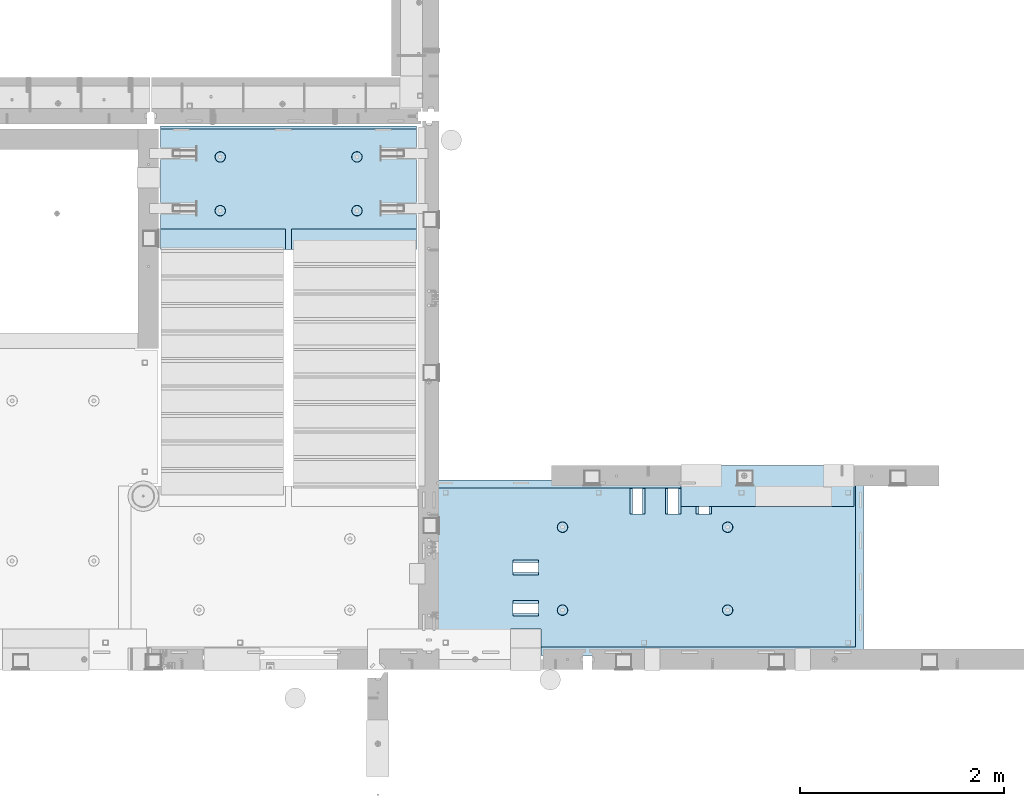
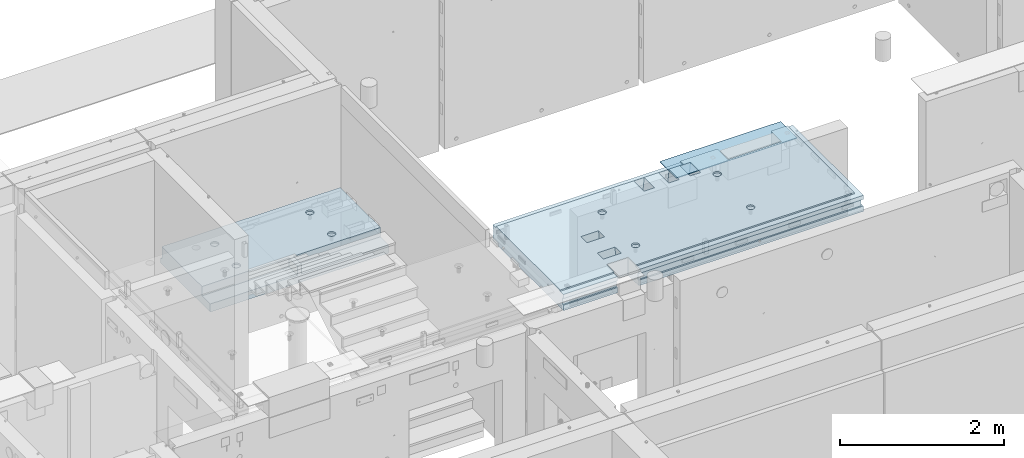
# One storey, part 150 of 264: 2 slabs, 1 plate, 3 elements without a shape of their own.
"""IFC2X3 building model written with IfcOpenShell, lengths in millimetres."""

from ifc_helpers import new_model, si_unit, frame, origin_with_axes, place, context, subcontext, project, spatial, faceted_brep, material, type_object, element, aggregate, save


model = new_model("IFC2X3")

# Units and contexts
model_context = context("Model", 3, precision=1e-05, world=origin_with_axes())
body_context = subcontext(model_context, "Body", "Model", "MODEL_VIEW")
ifc_project = project(units=[si_unit("LENGTHUNIT", "METRE", prefix="MILLI"), si_unit("AREAUNIT", "SQUARE_METRE"), si_unit("VOLUMEUNIT", "CUBIC_METRE"), si_unit("MASSUNIT", "GRAM", prefix="KILO"), si_unit("TIMEUNIT", "SECOND"), si_unit("PLANEANGLEUNIT", "RADIAN"), si_unit("SOLIDANGLEUNIT", "STERADIAN"), si_unit("THERMODYNAMICTEMPERATUREUNIT", "DEGREE_CELSIUS"), si_unit("LUMINOUSINTENSITYUNIT", "LUMEN")], contexts=[model_context])

# Site, building, storey
site_placement = place(None, origin_with_axes())
site = spatial("IfcSite", under=ifc_project, at=site_placement, CompositionType="ELEMENT")
building_placement = place(site_placement, origin_with_axes())
building = spatial("IfcBuilding", under=site, at=building_placement, CompositionType="ELEMENT")
storey_placement = place(building_placement, origin_with_axes())
storey = spatial("IfcBuildingStorey", under=building, at=storey_placement, Name="K", CompositionType="ELEMENT", Elevation=0.0)

# Assembly, slab
assembly_1_placement = place(storey_placement, origin_with_axes())
assembly_1 = element("IfcElementAssembly", 1, at=assembly_1_placement, inside=storey, AssemblyPlace="NOTDEFINED", PredefinedType="REINFORCEMENT_UNIT")
ifc_material_1 = material(Name="CONCRETE/C25/30")
slab_type_1 = type_object("IfcSlabType", PredefinedType="NOTDEFINED")
slab_1_placement = place(assembly_1_placement, frame((26570.0059390845, 15220.0026483125, 81620.0), z_axis=(-0.999999999997437, -2.26400000064461e-06, 0.0), x_axis=(-1.19799915409591e-06, 0.999999999999282, 0.0)))
slab_1 = element("IfcSlab", 2, at=slab_1_placement, type_object=slab_type_1, material=ifc_material_1, PredefinedType="FLOOR", context=body_context, shape_type="Brep", body=[
    faceted_brep([(1385.36870807312, -130.0, 2138.91585058365), (1385.36875512311, 130.0, 2163.91585058361), (1385.36894332312, 130.0, 2263.91585058343), (1385.36899037312, -130.0, 2288.91585058339), (1635.36894332267, 130.0, 2263.91538008343), (1635.36899037267, -130.0, 2288.91538008338), (1635.36875512267, 130.0, 2163.91538008361), (1635.36870807267, -130.0, 2138.91538008365), (458.263745513308, -110.000000000015, 1283.90255309084), (472.202158409184, -110.000000000015, 1291.00452918684), (483.263745513306, -110.000000000015, 1302.06611629097), (490.365721609318, -110.000000000015, 1316.00452918684), (492.812895794559, -110.000000000015, 1331.45537890559), (490.365721609318, -110.000000000015, 1346.90622862434), (483.263745513308, -110.000000000015, 1360.84464152022), (472.202158409185, -110.000000000015, 1371.90622862434), (458.263745513306, -110.000000000015, 1379.00820472035), (442.812895794559, -110.000000000015, 1381.45537890559), (427.362046075812, -110.000000000015, 1379.00820472035), (413.423633179937, -110.000000000015, 1371.90622862434), (402.362046075814, -110.000000000015, 1360.84464152021), (395.260069979802, -110.000000000015, 1346.90622862434), (392.812895794561, -110.000000000015, 1331.45537890559), (395.260069979802, -110.000000000015, 1316.00452918685), (402.362046075814, -110.000000000015, 1302.06611629097), (413.423633179937, -110.000000000015, 1291.00452918684), (427.362046075812, -110.000000000015, 1283.90255309084), (442.812895794559, -110.000000000015, 1281.45537890559), (458.966056864158, -130.0, 1281.74106100835), (442.812895794559, -130.0, 1279.18265163287), (473.538033982575, -130.0, 1289.16585419963), (485.102420500521, -130.0, 1300.73024071758), (492.527213691805, -130.0, 1315.302217836), (495.085623067285, -130.0, 1331.4553789056), (492.527213691805, -130.0, 1347.60853997519), (485.102420500521, -130.0, 1362.18051709361), (473.538033982575, -130.0, 1373.74490361155), (458.966056864158, -130.0, 1381.16969680284), (442.812895794561, -130.0, 1383.72810617832), (426.659734724963, -130.0, 1381.16969680284), (412.087757606545, -130.0, 1373.74490361156), (400.523371088597, -130.0, 1362.18051709361), (393.098577897315, -130.0, 1347.60853997519), (390.540168521833, -130.0, 1331.45537890559), (393.098577897317, -130.0, 1315.302217836), (400.523371088597, -130.0, 1300.73024071758), (412.087757606545, -130.0, 1289.16585419963), (426.659734724963, -130.0, 1281.74106100835), (1271.26411135405, -110.000000000029, 1283.90235358015), (1285.20252424993, -110.000000000029, 1291.00432967615), (1296.26411135405, -110.000000000029, 1302.06591678028), (1303.36608745006, -110.000000000029, 1316.00432967615), (1305.8132616353, -110.000000000029, 1331.4551793949), (1303.36608745006, -110.000000000029, 1346.90602911365), (1296.26411135405, -110.000000000029, 1360.84444200953), (1285.20252424992, -110.000000000029, 1371.90602911365), (1271.26411135405, -110.000000000029, 1379.00800520966), (1255.8132616353, -110.000000000029, 1381.4551793949), (1240.36241191655, -110.000000000029, 1379.00800520966), (1226.42399902068, -110.000000000029, 1371.90602911365), (1215.36241191655, -110.000000000029, 1360.84444200953), (1208.26043582054, -110.000000000029, 1346.90602911365), (1205.8132616353, -110.000000000029, 1331.45517939491), (1208.26043582054, -110.000000000029, 1316.00432967616), (1215.36241191655, -110.000000000029, 1302.06591678028), (1226.42399902068, -110.000000000029, 1291.00432967615), (1240.36241191655, -110.000000000029, 1283.90235358015), (1255.8132616353, -110.000000000029, 1281.4551793949), (1271.9664227049, -130.000000000015, 1281.74086149766), (1255.8132616353, -130.000000000015, 1279.18245212218), (1286.53839982332, -130.000000000015, 1289.16565468894), (1298.10278634126, -130.000000000015, 1300.73004120689), (1305.52757953255, -130.000000000015, 1315.30201832531), (1308.08598890803, -130.000000000015, 1331.45517939491), (1305.52757953255, -130.000000000015, 1347.6083404645), (1298.10278634126, -130.000000000015, 1362.18031758292), (1286.53839982331, -130.000000000015, 1373.74470410086), (1271.9664227049, -130.000000000015, 1381.16949729215), (1255.8132616353, -130.000000000015, 1383.72790666763), (1239.6601005657, -130.000000000015, 1381.16949729215), (1225.08812344729, -130.000000000015, 1373.74470410087), (1213.52373692934, -130.000000000015, 1362.18031758292), (1206.09894373805, -130.000000000015, 1347.6083404645), (1203.54053436257, -130.000000000015, 1331.4551793949), (1206.09894373805, -130.000000000015, 1315.30201832531), (1213.52373692934, -130.000000000015, 1300.73004120689), (1225.08812344729, -130.000000000015, 1289.16565468894), (1239.6601005657, -130.000000000015, 1281.74086149766), (1720.0078125, -110.000000000058, 4220.00537109375), (1640.00785561641, -110.000000000058, 4220.00536941853), (1640.00717842003, -110.000000000058, 1585.00001978694), (1720.00717842002, -110.000000000058, 1584.99999922694), (1700.00783630079, -49.9988643791585, 4220.00536608345), (1700.00717879947, -49.9988643791585, 1590.00006867175), (1700.00717879947, 50.0011356208415, 1590.00006867175), (1700.00783630079, 50.0011356208415, 4220.00536608345), (1720.00717879946, -49.9988643791585, 1590.00006367175), (1720.0078125, -49.9988643791585, 4220.00537109375), (1720.00717879946, 50.0011356208415, 1590.00006367175), (1720.0078125, 50.0011356208415, 4220.00537109375), (80.0079397798982, -130.0, 4220.00537109375), (80.0079397798982, -110.0, 4220.00537109375), (80.0065125017172, -110.0, 3460.00633932487), (80.0065125017172, -130.0, 3460.00633932487), (0.00793957244968624, -110.0, 4220.00537109375), (0.00650970076640078, -110.0, 3460.00648988487), (0.00793957244968624, -49.9988643791585, 4220.00537109375), (0.00650700578989927, -49.9989281829476, 3460.00648988488), (20.0078367270526, -49.9988643791585, 4220.0085543455), (20.0078367270526, 50.0011356208415, 4220.0085543455), (20.0071793252464, 50.0010725588945, 3460.00645224361), (20.0071793252337, -49.9988643791585, 3460.00645224361), (0.00793957244968624, 50.0011356208415, 4220.00537109375), (0.0065032962756959, 50.0010718170524, 3460.00648988488), (0.00793957244968624, 130.0, 4220.00537109375), (0.00650970076640078, 130.0, 3460.00648988487), (1720.0041715925, 50.0011356208415, 20.0000631346302), (1720.0041920925, -49.9988643791585, 20.0000631345902), (20.0042037196527, -49.9988643791585, 20.0000019345935), (20.0042037197236, 50.0007871208509, 20.0000019346335), (1720.0041928125, -49.9988643791585, 6.31345901638269e-05), (20.0041864226587, -49.9992128791491, 7.34271452529356e-07), (0.0, -49.9992169800098, -3.63797880709171e-12), (2.27349282795331e-05, -49.9992169800098, 20.000001214441), (1720.00415040489, -110.0, -7.82736606197432e-07), (80.0000146155362, -110.0, 0.000114017555461032), (40.0000000237706, -110.0, 0.00323799208854325), (1.81898940354586e-12, -110.000000000058, 0.0), (1720.00415600489, -110.0, 79.9999992172634), (80.0001648500238, -110.0, 80.0001140175445), (40.0000056179106, -110.0, 80.000116817555), (80.0059490995409, -110.0, 3160.00517965743), (0.00594527472276241, -110.0, 3160.00533021743), (0.00594151593395509, -49.9989533687913, 3160.00533021744), (20.0069198242309, -49.9988643791585, 3160.0052925756), (20.0069198242491, 50.0010476659954, 3160.0052925756), (2.23492861550767e-06, 50.0007830199902, 20.0000012144774), (0.00593634212964389, 50.0010466312087, 3160.00533021745), (0.0, 130.0, -1.81898940354586e-12), (0.0, 50.0007830199902, -3.63797880709171e-12), (0.00594527472276241, 130.0, 3160.00533021743), (20.0041864225386, 50.0007871208509, -3.03407432511449e-09), (1720.00415039538, 50.0011356208415, -2.60683009400964e-07), (1720.00415039063, 130.0, 3.38332029059529e-10), (1720.00421981442, -130.0, 79.9999992172052), (1720.00441940968, 130.0, 310.002169469204), (1720.00441860991, -130.000000000015, 310.002169469204), (80.0001648500238, -130.0, 80.0001140175445), (80.0059490995409, -130.0, 3160.00517965743), (260.003595423286, -130.0, 3160.00484090186), (260.003595423286, 130.0, 3160.00484090186), (260.004160025468, -130.0, 3460.00600056929), (260.004160025468, 130.0, 3460.00600056929), (1640.00785561641, -130.0, 4220.00537109375), (1720.0078125, 130.0, 4220.00537109375), (1640.00717842003, -130.000000000058, 1585.00001978694), (1720.00717842002, -130.000000000058, 1584.99999922694), (1720.00614635257, -130.000000000044, 1060.00216946755), (1720.00507025768, 130.0, 1060.00216946504), (1459.99926883107, -130.000000000015, 1060.00265880023), (1459.99926883107, 130.0, 1060.00265880023), (1459.99785733107, -130.000000000015, 310.002658801553), (1459.99785733107, 130.0, 310.002658801553), (458.266791003349, -110.000000000015, 2902.12255308797), (472.205203899226, -110.000000000015, 2909.22452918398), (483.266791003347, -110.000000000015, 2920.28611628811), (490.368767099359, -110.000000000015, 2934.22452918398), (492.8159412846, -110.000000000015, 2949.67537890273), (490.368767099359, -110.000000000015, 2965.12622862148), (483.266791003349, -110.000000000015, 2979.06464151735), (472.205203899226, -110.000000000015, 2990.12622862148), (458.266791003347, -110.000000000015, 2997.22820471749), (442.8159412846, -110.000000000015, 2999.67537890273), (427.365091565853, -110.000000000015, 2997.22820471749), (413.426678669977, -110.000000000015, 2990.12622862148), (402.365091565855, -110.000000000015, 2979.06464151735), (395.263115469843, -110.000000000015, 2965.12622862148), (392.815941284602, -110.000000000015, 2949.67537890273), (395.263115469843, -110.000000000015, 2934.22452918399), (402.365091565855, -110.000000000015, 2920.2861162881), (413.426678669977, -110.000000000015, 2909.22452918398), (427.365091565855, -110.000000000015, 2902.12255308797), (442.8159412846, -110.000000000015, 2899.67537890273), (458.969102354198, -130.0, 2899.96106100548), (442.8159412846, -130.0, 2897.40265163), (473.541079472616, -130.0, 2907.38585419677), (485.105465990562, -130.0, 2918.95024071472), (492.530259181845, -130.0, 2933.52221783313), (495.088668557326, -130.0, 2949.67537890273), (492.530259181845, -130.0, 2965.82853997233), (485.105465990562, -130.0, 2980.40051709074), (473.541079472616, -130.0, 2991.96490360869), (458.969102354198, -130.0, 2999.38969679998), (442.815941284602, -130.0, 3001.94810617546), (426.662780215003, -130.0, 2999.38969679998), (412.090803096586, -130.0, 2991.96490360869), (400.526416578641, -129.999999999985, 2980.40051709074), (393.101623387358, -129.999999999985, 2965.82853997233), (390.543214011877, -129.999999999985, 2949.67537890273), (393.10162338736, -129.999999999985, 2933.52221783313), (400.526416578638, -130.0, 2918.95024071472), (412.090803096586, -130.0, 2907.38585419677), (426.662780215003, -130.0, 2899.96106100548), (1271.26715684409, -110.000000000029, 2902.12235357728), (1285.20556973997, -110.000000000029, 2909.22432967329), (1296.26715684409, -110.000000000029, 2920.28591677742), (1303.3691329401, -110.000000000029, 2934.22432967329), (1305.81630712534, -110.000000000029, 2949.67517939204), (1303.3691329401, -110.000000000029, 2965.12602911079), (1296.26715684409, -110.000000000029, 2979.06444200667), (1285.20556973996, -110.000000000029, 2990.12602911079), (1271.26715684409, -110.000000000029, 2997.2280052068), (1255.81630712534, -110.000000000029, 2999.67517939204), (1240.36545740659, -110.000000000029, 2997.2280052068), (1226.42704451072, -110.000000000029, 2990.12602911079), (1215.36545740659, -110.000000000029, 2979.06444200666), (1208.26348131059, -110.000000000029, 2965.12602911079), (1205.81630712534, -110.000000000029, 2949.67517939204), (1208.26348131059, -110.000000000029, 2934.2243296733), (1215.36545740659, -110.000000000029, 2920.28591677741), (1226.42704451072, -110.000000000029, 2909.22432967329), (1240.36545740659, -110.000000000029, 2902.12235357728), (1255.81630712534, -110.000000000029, 2899.67517939204), (1271.96946819494, -130.000000000015, 2899.96086149479), (1255.81630712534, -130.000000000015, 2897.40245211931), (1286.54144531336, -130.000000000015, 2907.38565468608), (1298.1058318313, -130.000000000015, 2918.95004120403), (1305.53062502259, -130.000000000015, 2933.52201832244), (1308.08903439807, -130.000000000015, 2949.67517939204), (1305.53062502259, -130.000000000015, 2965.82834046164), (1298.1058318313, -130.000000000015, 2980.40031758005), (1286.54144531335, -130.000000000015, 2991.964704098), (1271.96946819494, -130.000000000015, 2999.38949728928), (1255.81630712534, -130.000000000015, 3001.94790666477), (1239.66314605574, -130.000000000015, 2999.38949728929), (1225.09116893733, -130.000000000015, 2991.964704098), (1213.52678241938, -130.000000000015, 2980.40031758005), (1206.10198922809, -130.000000000015, 2965.82834046164), (1203.54357985261, -130.000000000015, 2949.67517939204), (1206.10198922809, -130.000000000015, 2933.52201832244), (1213.52678241938, -130.000000000015, 2918.95004120403), (1225.09116893733, -130.000000000015, 2907.38565468608), (1239.66314605574, -130.000000000015, 2899.96086149479), (535.006335132097, -130.0, 3435.00760126515), (510.006335132142, 130.0, 3435.00764831515), (510.005864632141, 130.0, 3185.00764831559), (535.005864632096, -130.0, 3185.00760126559), (385.006335132362, -130.0, 3435.00788356515), (410.006335132319, 130.0, 3435.00783651515), (385.005864632361, -130.0, 3185.00788356559), (410.005864632318, 130.0, 3185.00783651559), (935.006335131389, -130.0, 3435.00684846515), (910.006335131433, 130.0, 3435.00689551515), (910.005864631432, 130.0, 3185.00689551559), (935.005864631388, -130.0, 3185.00684846559), (785.006335131655, -130.0, 3435.00713076515), (810.006335131611, 130.0, 3435.00708371515), (785.005864631654, -130.0, 3185.00713076559), (810.00586463161, 130.0, 3185.00708371559), (1635.36776707267, -130.0, 1638.91538008453), (1635.36772002267, 130.0, 1613.91538008458), (1635.36753182267, 130.0, 1513.91538008476), (1635.36748477267, -130.0, 1488.9153800848), (1385.36776707311, -130.0, 1638.91585058454), (1385.36772002312, 130.0, 1613.91585058458), (1385.36748477311, -130.0, 1488.9158505848), (1385.36753182312, 130.0, 1513.91585058476), (1385.36833167312, -130.0, 1938.91585058401), (1635.36833167267, -130.0, 1938.915380084), (1635.36804937267, -130.0, 1788.91538008427), (1385.36804937312, -130.0, 1788.91585058427), (1635.36828462267, 130.0, 1913.91538008405), (1385.36828462312, 130.0, 1913.91585058405), (1385.36809642312, 130.0, 1813.91585058423), (1635.36809642267, 130.0, 1813.91538008423)], [[[0, 1, 2, 3]], [[4, 5, 3, 2]], [[5, 4, 6, 7]], [[7, 6, 1, 0]], [[8, 9, 10, 11, 12, 13, 14, 15, 16, 17, 18, 19, 20, 21, 22, 23, 24, 25, 26, 27]], [[28, 8, 27, 29]], [[30, 9, 8, 28]], [[31, 10, 9, 30]], [[32, 11, 10, 31]], [[33, 12, 11, 32]], [[34, 13, 12, 33]], [[35, 14, 13, 34]], [[36, 15, 14, 35]], [[37, 16, 15, 36]], [[38, 17, 16, 37]], [[39, 18, 17, 38]], [[40, 19, 18, 39]], [[41, 20, 19, 40]], [[42, 21, 20, 41]], [[43, 22, 21, 42]], [[44, 23, 22, 43]], [[45, 24, 23, 44]], [[46, 25, 24, 45]], [[47, 26, 25, 46]], [[29, 27, 26, 47]], [[48, 49, 50, 51, 52, 53, 54, 55, 56, 57, 58, 59, 60, 61, 62, 63, 64, 65, 66, 67]], [[68, 48, 67, 69]], [[70, 49, 48, 68]], [[71, 50, 49, 70]], [[72, 51, 50, 71]], [[73, 52, 51, 72]], [[74, 53, 52, 73]], [[75, 54, 53, 74]], [[76, 55, 54, 75]], [[77, 56, 55, 76]], [[78, 57, 56, 77]], [[79, 58, 57, 78]], [[80, 59, 58, 79]], [[81, 60, 59, 80]], [[82, 61, 60, 81]], [[83, 62, 61, 82]], [[84, 63, 62, 83]], [[85, 64, 63, 84]], [[86, 65, 64, 85]], [[87, 66, 65, 86]], [[69, 67, 66, 87]], [[88, 89, 90, 91]], [[92, 93, 94, 95]], [[96, 93, 92, 97]], [[98, 94, 93, 96]], [[99, 95, 94, 98]], [[100, 101, 102, 103]], [[101, 104, 105, 102]], [[104, 106, 107, 105]], [[108, 109, 110, 111]], [[109, 112, 113, 110]], [[112, 114, 115, 113]], [[116, 117, 118, 119]], [[117, 120, 121, 122, 123, 118]], [[120, 124, 125, 126, 127, 122, 121]], [[125, 124, 128, 129, 130, 126]], [[127, 126, 130, 129, 131, 132]], [[123, 122, 127, 132, 133]], [[118, 123, 133, 134]], [[119, 118, 134, 135]], [[136, 119, 135, 137]], [[138, 139, 136, 137, 140]], [[141, 142, 116, 119, 136, 139]], [[139, 138, 143, 142, 141]], [[144, 128, 124, 120, 117, 116, 142, 143, 145, 146]], [[128, 144, 147, 129]], [[129, 147, 148, 131]], [[149, 150, 140, 137, 135, 134, 133, 132, 131, 148]], [[151, 152, 150, 149]], [[103, 102, 105, 107, 111, 110, 113, 115, 152, 151]], [[106, 108, 111, 107]], [[104, 101, 100, 153, 89, 88, 97, 92, 95, 99, 154, 114, 112, 109, 108, 106]], [[155, 90, 89, 153]], [[156, 91, 90, 155]], [[154, 99, 98, 96, 97, 88, 91, 156, 157, 158]], [[157, 159, 160, 158]], [[161, 162, 160, 159]], [[146, 145, 162, 161]], [[163, 164, 165, 166, 167, 168, 169, 170, 171, 172, 173, 174, 175, 176, 177, 178, 179, 180, 181, 182]], [[183, 163, 182, 184]], [[185, 164, 163, 183]], [[186, 165, 164, 185]], [[187, 166, 165, 186]], [[188, 167, 166, 187]], [[189, 168, 167, 188]], [[190, 169, 168, 189]], [[191, 170, 169, 190]], [[192, 171, 170, 191]], [[193, 172, 171, 192]], [[194, 173, 172, 193]], [[195, 174, 173, 194]], [[196, 175, 174, 195]], [[197, 176, 175, 196]], [[198, 177, 176, 197]], [[199, 178, 177, 198]], [[200, 179, 178, 199]], [[201, 180, 179, 200]], [[202, 181, 180, 201]], [[184, 182, 181, 202]], [[203, 204, 205, 206, 207, 208, 209, 210, 211, 212, 213, 214, 215, 216, 217, 218, 219, 220, 221, 222]], [[223, 203, 222, 224]], [[225, 204, 203, 223]], [[226, 205, 204, 225]], [[227, 206, 205, 226]], [[228, 207, 206, 227]], [[229, 208, 207, 228]], [[230, 209, 208, 229]], [[231, 210, 209, 230]], [[232, 211, 210, 231]], [[233, 212, 211, 232]], [[234, 213, 212, 233]], [[235, 214, 213, 234]], [[236, 215, 214, 235]], [[237, 216, 215, 236]], [[238, 217, 216, 237]], [[239, 218, 217, 238]], [[240, 219, 218, 239]], [[241, 220, 219, 240]], [[242, 221, 220, 241]], [[224, 222, 221, 242]], [[243, 244, 245, 246]], [[247, 248, 244, 243]], [[248, 247, 249, 250]], [[246, 245, 250, 249]], [[251, 252, 253, 254]], [[255, 256, 252, 251]], [[256, 255, 257, 258]], [[254, 253, 258, 257]], [[259, 260, 261, 262]], [[260, 259, 263, 264]], [[265, 266, 264, 263]], [[262, 261, 266, 265]], [[159, 157, 156, 155, 153, 100, 103, 151, 149, 148, 147, 144, 146, 161], [3, 5, 7, 0], [267, 268, 269, 270], [263, 259, 262, 265], [255, 251, 254, 257], [247, 243, 246, 249], [241, 240, 239, 238, 237, 236, 235, 234, 233, 232, 231, 230, 229, 228, 227, 226, 225, 223, 224, 242], [201, 200, 199, 198, 197, 196, 195, 194, 193, 192, 191, 190, 189, 188, 187, 186, 185, 183, 184, 202], [86, 85, 84, 83, 82, 81, 80, 79, 78, 77, 76, 75, 74, 73, 72, 71, 70, 68, 69, 87], [46, 45, 44, 43, 42, 41, 40, 39, 38, 37, 36, 35, 34, 33, 32, 31, 30, 28, 29, 47]], [[271, 268, 267, 272]], [[270, 273, 272, 267]], [[269, 274, 273, 270]], [[268, 271, 274, 269]], [[143, 138, 140, 150, 152, 115, 114, 154, 158, 160, 162, 145], [2, 1, 6, 4], [272, 273, 274, 271], [264, 266, 261, 260], [256, 258, 253, 252], [248, 250, 245, 244]]]),
])
aggregate(assembly_1, [slab_1])

# Assembly, plate
assembly_2_placement = place(storey_placement, origin_with_axes())
assembly_2 = element("IfcElementAssembly", 3, at=assembly_2_placement, inside=storey, Name="Steel Assembly", AssemblyPlace="NOTDEFINED", PredefinedType="NOTDEFINED")
ifc_material_2 = material()
plate_type = type_object("IfcPlateType", PredefinedType="NOTDEFINED")
plate_placement = place(assembly_2_placement, frame((24780.0, 16680.0, 81725.6000003815), z_axis=(0.0, 1.0, 0.0), x_axis=(1.0, 0.0, 0.0)))
plate = element("IfcPlate", 4, at=plate_placement, type_object=plate_type, material=ifc_material_2, Name="YP", context=body_context, shape_type="Brep", body=[
    faceted_brep([(0.0, -5.0, 0.0), (0.0, -5.0, 400.0), (0.0, 5.0, 400.0), (0.0, 5.0, 0.0), (1699.99914550781, -5.0, 400.0), (1699.99914550781, 5.0, 400.0), (1699.99914550781, -5.0, 3.63797880709171e-12), (1699.99914550781, 5.0, 3.63797880709171e-12)], [[[0, 1, 2, 3]], [[1, 4, 5, 2]], [[4, 6, 7, 5]], [[6, 0, 3, 7]], [[5, 7, 3, 2]], [[6, 4, 1, 0]]]),
])
aggregate(assembly_2, [plate])

# Assembly, slab
assembly_3_placement = place(storey_placement, origin_with_axes())
assembly_3 = element("IfcElementAssembly", 5, at=assembly_3_placement, inside=storey, AssemblyPlace="NOTDEFINED", PredefinedType="REINFORCEMENT_UNIT")
slab_type_2 = type_object("IfcSlabType", PredefinedType="NOTDEFINED")
slab_2_placement = place(assembly_3_placement, frame((19680.000385927, 19200.0003517906, 80120.0), z_axis=(0.0, 1.0, 0.0), x_axis=(1.0, 0.0, 0.0)))
slab_2 = element("IfcSlab", 6, at=slab_2_placement, type_object=slab_type_2, material=ifc_material_1, PredefinedType="FLOOR", context=body_context, shape_type="Brep", body=[
    faceted_brep([(1284.99890682963, -130.0, 0.0), (1284.99890682963, 10.0003972196719, 0.0), (1284.99890682963, 10.0003972196719, 200.003967285156), (1284.99890682963, -130.0, 200.003967285156), (2510.00073788432, 10.0003972196719, 200.003967285156), (2509.998046875, 10.0003972196719, 0.0), (2510.00073788432, -130.0, 200.003967285156), (2509.998046875, 60.0, 1210.00146484375), (0.0, 60.0, 1210.00146484375), (0.0, 50.0000001803419, 1180.00146538467), (2509.998046875, 50.0000001803419, 1180.00146538467), (2509.998046875, 130.0, 1210.00146484375), (0.0, 130.0, 1210.00146484375), (2509.998046875, 130.0, 0.0), (0.0, 130.0, -1.81898940354586e-12), (1225.00073788432, 10.0003972196719, 0.0), (1225.00073788432, 10.0003972196719, 200.003967285156), (-0.00109317036549328, 10.0003972196719, 200.003967285156), (0.0, 10.0003972196719, 0.0), (1225.00073788432, -130.0, 200.003967285156), (1225.00073788432, -130.0, 0.0), (0.0, -130.0, 200.003967285156), (0.0, -130.0, 1180.00146417833), (2509.998046875, -130.0, 1180.00146417833), (1940.44809334572, -110.0, 331.258272818675), (1954.3865062416, -110.0, 338.360248914683), (1965.44809334572, -110.0, 349.42183601881), (1972.55006944173, -110.0, 363.360248914683), (1974.99724362697, -110.0, 378.811098633432), (1972.55006944173, -110.0, 394.261948352181), (1965.44809334572, -110.0, 408.200361248055), (1954.3865062416, -110.0, 419.261948352181), (1940.44809334572, -110.0, 426.363924448189), (1924.99724362697, -110.0, 428.811098633432), (1909.54639390823, -110.0, 426.363924448189), (1895.60798101235, -110.0, 419.261948352181), (1884.54639390823, -110.0, 408.200361248055), (1877.44441781222, -110.0, 394.261948352181), (1874.99724362697, -110.0, 378.811098633432), (1877.44441781222, -110.0, 363.360248914683), (1884.54639390823, -110.0, 349.42183601881), (1895.60798101235, -110.0, 338.360248914683), (1909.54639390823, -110.0, 331.258272818675), (1924.99724362697, -110.0, 328.811098633432), (1974.71156152422, -130.0, 394.964259703032), (1977.2699708997, -130.0, 378.811098633432), (1967.28676833294, -130.0, 409.536236821448), (1955.72238181499, -130.0, 421.100623339393), (1941.15040469657, -130.0, 428.52541653068), (1924.99724362697, -130.0, 431.08382590616), (1908.84408255737, -130.0, 428.52541653068), (1894.27210543896, -130.0, 421.100623339393), (1882.70771892101, -130.0, 409.536236821448), (1875.28292572973, -130.0, 394.964259703032), (1872.72451635425, -130.0, 378.811098633432), (1875.28292572973, -130.0, 362.657937563832), (1882.70771892101, -130.0, 348.085960445416), (1894.27210543896, -130.0, 336.521573927472), (1908.84408255737, -130.0, 329.096780736185), (1924.99724362697, -130.0, 326.538371360704), (1941.15040469657, -130.0, 329.096780736185), (1955.72238181499, -130.0, 336.521573927472), (1967.28676833294, -130.0, 348.085960445416), (1974.71156152422, -130.0, 362.657937563832), (1940.44809334572, -110.0, 858.458272818676), (1954.3865062416, -110.0, 865.560248914684), (1965.44809334572, -110.0, 876.62183601881), (1972.55006944173, -110.0, 890.560248914684), (1974.99724362697, -110.0, 906.011098633433), (1972.55006944173, -110.0, 921.461948352182), (1965.44809334572, -110.0, 935.400361248056), (1954.3865062416, -110.0, 946.461948352182), (1940.44809334572, -110.0, 953.56392444819), (1924.99724362697, -110.0, 956.011098633433), (1909.54639390823, -110.0, 953.56392444819), (1895.60798101235, -110.0, 946.461948352182), (1884.54639390823, -110.0, 935.400361248056), (1877.44441781222, -110.0, 921.461948352182), (1874.99724362697, -110.0, 906.011098633433), (1877.44441781222, -110.0, 890.560248914684), (1884.54639390823, -110.0, 876.62183601881), (1895.60798101235, -110.0, 865.560248914684), (1909.54639390823, -110.0, 858.458272818676), (1924.99724362697, -110.0, 856.011098633433), (1974.71156152422, -130.0, 922.164259703033), (1977.2699708997, -130.0, 906.011098633433), (1967.28676833294, -130.0, 936.736236821449), (1955.72238181499, -130.0, 948.300623339394), (1941.15040469657, -130.0, 955.72541653068), (1924.99724362697, -130.0, 958.283825906161), (1908.84408255737, -130.0, 955.72541653068), (1894.27210543896, -130.0, 948.300623339394), (1882.70771892101, -130.0, 936.736236821449), (1875.28292572973, -130.0, 922.164259703033), (1872.72451635425, -130.0, 906.011098633433), (1875.28292572973, -130.0, 889.857937563833), (1882.70771892101, -130.0, 875.285960445417), (1894.27210543896, -130.0, 863.721573927472), (1908.84408255737, -130.0, 856.296780736186), (1924.99724362697, -130.0, 853.738371360705), (1941.15040469657, -130.0, 856.296780736186), (1955.72238181499, -130.0, 863.721573927472), (1967.28676833294, -130.0, 875.285960445417), (1974.71156152422, -130.0, 889.857937563833), (569.611134800252, -110.0, 426.363924448189), (555.672721904379, -110.0, 419.261948352181), (544.611134800252, -110.0, 408.200361248055), (537.509158704244, -110.0, 394.261948352181), (535.061984519001, -110.0, 378.811098633432), (537.509158704244, -110.0, 363.360248914683), (544.611134800252, -110.0, 349.42183601881), (555.672721904379, -110.0, 338.360248914683), (569.611134800252, -110.0, 331.258272818675), (585.061984519001, -110.0, 328.811098633432), (600.51283423775, -110.0, 331.258272818675), (614.451247133624, -110.0, 338.360248914683), (625.51283423775, -110.0, 349.42183601881), (632.614810333758, -110.0, 363.360248914683), (635.061984519001, -110.0, 378.811098633432), (632.614810333758, -110.0, 394.261948352181), (625.51283423775, -110.0, 408.200361248055), (614.451247133624, -110.0, 419.261948352181), (600.51283423775, -110.0, 426.363924448189), (585.061984519001, -110.0, 428.811098633432), (634.776302416249, -130.0, 394.964259703032), (637.334711791729, -130.0, 378.811098633432), (627.351509224962, -130.0, 409.536236821448), (615.787122707017, -130.0, 421.100623339393), (601.215145588601, -130.0, 428.52541653068), (585.061984519001, -130.0, 431.08382590616), (568.908823449401, -130.0, 428.52541653068), (554.336846330985, -130.0, 421.100623339393), (542.772459813041, -130.0, 409.536236821448), (535.347666621754, -130.0, 394.964259703032), (532.789257246273, -130.0, 378.811098633432), (535.347666621754, -130.0, 362.657937563832), (542.772459813041, -130.0, 348.085960445416), (554.336846330985, -130.0, 336.521573927472), (568.908823449401, -130.0, 329.096780736185), (585.061984519001, -130.0, 326.538371360704), (601.215145588601, -130.0, 329.096780736185), (615.787122707017, -130.0, 336.521573927472), (627.351509224962, -130.0, 348.085960445416), (634.776302416249, -130.0, 362.657937563832), (569.611134800252, -110.0, 953.56392444819), (555.672721904379, -110.0, 946.461948352182), (544.611134800252, -110.0, 935.400361248056), (537.509158704244, -110.0, 921.461948352182), (535.061984519001, -110.0, 906.011098633433), (537.509158704244, -110.0, 890.560248914684), (544.611134800252, -110.0, 876.62183601881), (555.672721904379, -110.0, 865.560248914684), (569.611134800252, -110.0, 858.458272818676), (585.061984519001, -110.0, 856.011098633433), (600.51283423775, -110.0, 858.458272818676), (614.451247133624, -110.0, 865.560248914684), (625.51283423775, -110.0, 876.62183601881), (632.614810333758, -110.0, 890.560248914684), (635.061984519001, -110.0, 906.011098633433), (632.614810333758, -110.0, 921.461948352182), (625.51283423775, -110.0, 935.400361248056), (614.451247133624, -110.0, 946.461948352182), (600.51283423775, -110.0, 953.56392444819), (585.061984519001, -110.0, 956.011098633433), (634.776302416249, -130.0, 922.164259703033), (637.334711791729, -130.0, 906.011098633433), (627.351509224962, -130.0, 936.736236821449), (615.787122707017, -130.0, 948.300623339394), (601.215145588601, -130.0, 955.72541653068), (585.061984519001, -130.0, 958.283825906161), (568.908823449401, -130.0, 955.72541653068), (554.336846330985, -130.0, 948.300623339394), (542.772459813041, -130.0, 936.736236821449), (535.347666621754, -130.0, 922.164259703033), (532.789257246273, -130.0, 906.011098633433), (535.347666621754, -130.0, 889.857937563833), (542.772459813041, -130.0, 875.285960445417), (554.336846330985, -130.0, 863.721573927472), (568.908823449401, -130.0, 856.296780736186), (585.061984519001, -130.0, 853.738371360705), (601.215145588601, -130.0, 856.296780736186), (615.787122707017, -130.0, 863.721573927472), (627.351509224962, -130.0, 875.285960445417), (634.776302416249, -130.0, 889.857937563833)], [[[0, 1, 2, 3]], [[4, 2, 1, 5]], [[6, 3, 2, 4]], [[7, 8, 9, 10]], [[11, 12, 8, 7]], [[11, 13, 14, 12]], [[15, 16, 17, 18]], [[19, 16, 15, 20]], [[21, 17, 16, 19]], [[22, 9, 8, 12, 14, 18, 17, 21]], [[23, 10, 9, 22]], [[5, 13, 11, 7, 10, 23, 6, 4]], [[0, 20, 15, 18, 14, 13, 5, 1]], [[24, 25, 26, 27, 28, 29, 30, 31, 32, 33, 34, 35, 36, 37, 38, 39, 40, 41, 42, 43]], [[44, 29, 28, 45]], [[46, 30, 29, 44]], [[47, 31, 30, 46]], [[48, 32, 31, 47]], [[49, 33, 32, 48]], [[50, 34, 33, 49]], [[51, 35, 34, 50]], [[52, 36, 35, 51]], [[53, 37, 36, 52]], [[54, 38, 37, 53]], [[55, 39, 38, 54]], [[56, 40, 39, 55]], [[57, 41, 40, 56]], [[58, 42, 41, 57]], [[59, 43, 42, 58]], [[60, 24, 43, 59]], [[61, 25, 24, 60]], [[62, 26, 25, 61]], [[63, 27, 26, 62]], [[45, 28, 27, 63]], [[64, 65, 66, 67, 68, 69, 70, 71, 72, 73, 74, 75, 76, 77, 78, 79, 80, 81, 82, 83]], [[84, 69, 68, 85]], [[86, 70, 69, 84]], [[87, 71, 70, 86]], [[88, 72, 71, 87]], [[89, 73, 72, 88]], [[90, 74, 73, 89]], [[91, 75, 74, 90]], [[92, 76, 75, 91]], [[93, 77, 76, 92]], [[94, 78, 77, 93]], [[95, 79, 78, 94]], [[96, 80, 79, 95]], [[97, 81, 80, 96]], [[98, 82, 81, 97]], [[99, 83, 82, 98]], [[100, 64, 83, 99]], [[101, 65, 64, 100]], [[102, 66, 65, 101]], [[103, 67, 66, 102]], [[85, 68, 67, 103]], [[104, 105, 106, 107, 108, 109, 110, 111, 112, 113, 114, 115, 116, 117, 118, 119, 120, 121, 122, 123]], [[124, 119, 118, 125]], [[126, 120, 119, 124]], [[127, 121, 120, 126]], [[128, 122, 121, 127]], [[129, 123, 122, 128]], [[130, 104, 123, 129]], [[131, 105, 104, 130]], [[132, 106, 105, 131]], [[133, 107, 106, 132]], [[134, 108, 107, 133]], [[135, 109, 108, 134]], [[136, 110, 109, 135]], [[137, 111, 110, 136]], [[138, 112, 111, 137]], [[139, 113, 112, 138]], [[140, 114, 113, 139]], [[141, 115, 114, 140]], [[142, 116, 115, 141]], [[143, 117, 116, 142]], [[125, 118, 117, 143]], [[144, 145, 146, 147, 148, 149, 150, 151, 152, 153, 154, 155, 156, 157, 158, 159, 160, 161, 162, 163]], [[164, 159, 158, 165]], [[166, 160, 159, 164]], [[167, 161, 160, 166]], [[168, 162, 161, 167]], [[169, 163, 162, 168]], [[170, 144, 163, 169]], [[171, 145, 144, 170]], [[172, 146, 145, 171]], [[173, 147, 146, 172]], [[174, 148, 147, 173]], [[175, 149, 148, 174]], [[176, 150, 149, 175]], [[177, 151, 150, 176]], [[178, 152, 151, 177]], [[179, 153, 152, 178]], [[180, 154, 153, 179]], [[181, 155, 154, 180]], [[182, 156, 155, 181]], [[183, 157, 156, 182]], [[165, 158, 157, 183]], [[23, 22, 21, 19, 20, 0, 3, 6], [182, 181, 180, 179, 178, 177, 176, 175, 174, 173, 172, 171, 170, 169, 168, 167, 166, 164, 165, 183], [142, 141, 140, 139, 138, 137, 136, 135, 134, 133, 132, 131, 130, 129, 128, 127, 126, 124, 125, 143], [102, 101, 100, 99, 98, 97, 96, 95, 94, 93, 92, 91, 90, 89, 88, 87, 86, 84, 85, 103], [62, 61, 60, 59, 58, 57, 56, 55, 54, 53, 52, 51, 50, 49, 48, 47, 46, 44, 45, 63]]]),
])
aggregate(assembly_3, [slab_2])

save(model, "model.ifc")
